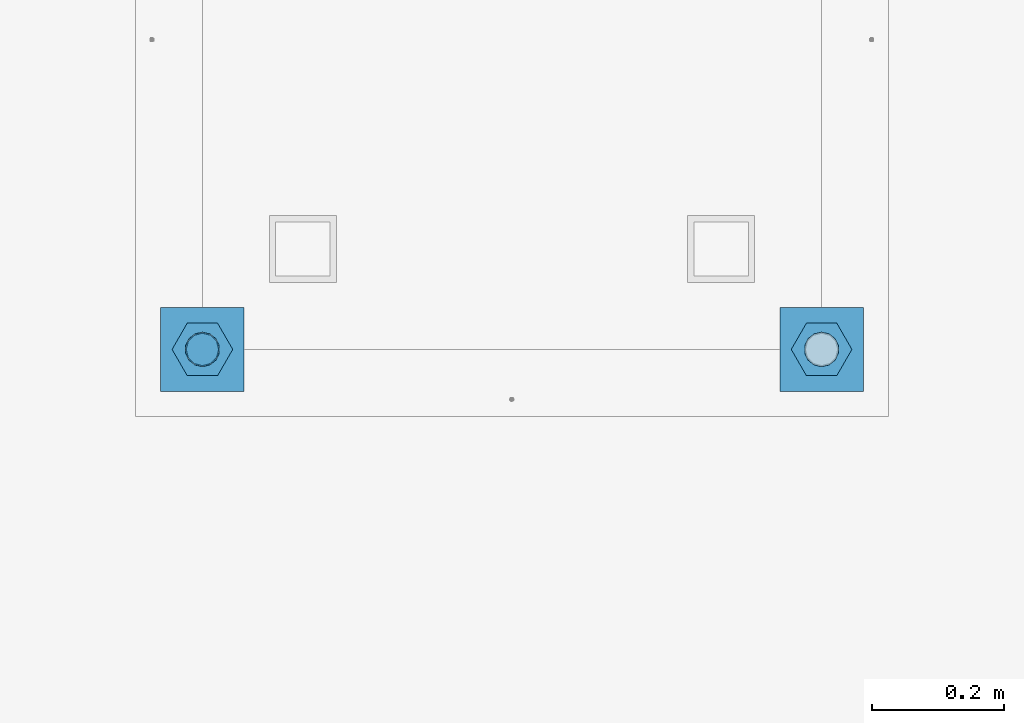
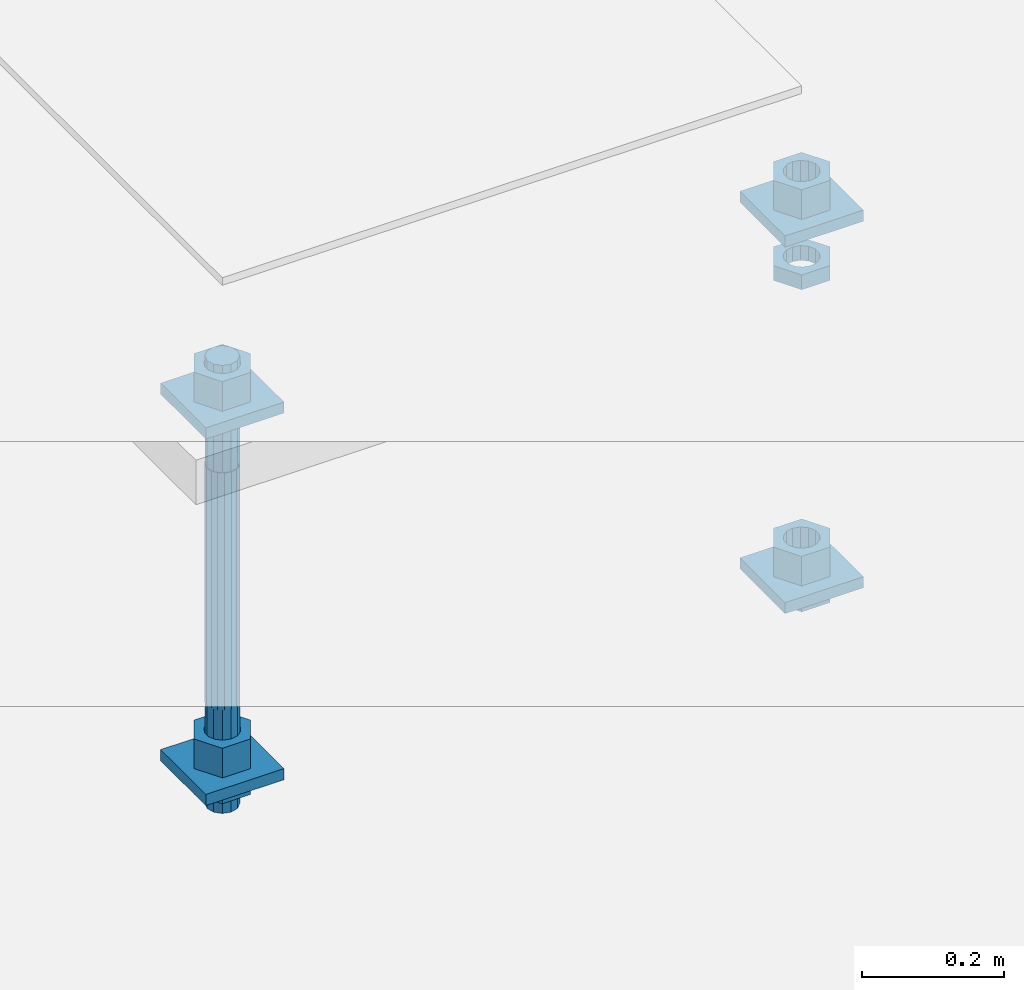
# One storey, part 2601 of 3843: 12 beams, 1 element without a shape of its own.
"""IFC2X3 building model written with IfcOpenShell, lengths in millimetres."""

from ifc_helpers import new_model, si_unit, frame, origin_with_axes, place, context, subcontext, project, spatial, faceted_brep, material, type_object, element, aggregate, save


model = new_model("IFC2X3")

# Units and contexts
model_context = context("Model", 3, precision=1e-05, world=origin_with_axes())
body_context = subcontext(model_context, "Body", "Model", "MODEL_VIEW")
ifc_project = project(units=[si_unit("LENGTHUNIT", "METRE", prefix="MILLI"), si_unit("AREAUNIT", "SQUARE_METRE"), si_unit("VOLUMEUNIT", "CUBIC_METRE"), si_unit("MASSUNIT", "GRAM", prefix="KILO"), si_unit("TIMEUNIT", "SECOND"), si_unit("PLANEANGLEUNIT", "RADIAN"), si_unit("SOLIDANGLEUNIT", "STERADIAN"), si_unit("THERMODYNAMICTEMPERATUREUNIT", "DEGREE_CELSIUS"), si_unit("LUMINOUSINTENSITYUNIT", "LUMEN")], contexts=[model_context])

# Site, building, storey
site_placement = place(None, origin_with_axes())
site = spatial("IfcSite", under=ifc_project, at=site_placement, CompositionType="ELEMENT")
building_placement = place(site_placement, origin_with_axes())
building = spatial("IfcBuilding", under=site, at=building_placement, Name="Undefined", CompositionType="ELEMENT")
storey_placement = place(building_placement, origin_with_axes())
storey = spatial("IfcBuildingStorey", under=building, at=storey_placement, Name="Undefined", CompositionType="ELEMENT", Elevation=0.0)

# Assembly, beams
assembly_placement = place(storey_placement, origin_with_axes())
assembly = element("IfcElementAssembly", 1, at=assembly_placement, inside=storey, Name="TEMPLATE", AssemblyPlace="NOTDEFINED", PredefinedType="RIGID_FRAME")
ifc_material_1 = material(Name="STEEL/A36")
beam_type_1 = type_object("IfcBeamType", PredefinedType="NOTDEFINED")
beam_1_placement = place(assembly_placement, frame((108483.4, 21551.9000015259, 29873.575), z_axis=(1.0, 0.0, 0.0), x_axis=(0.0, 1.0, 0.0)))
beam_1 = element("IfcBeam", 2, at=beam_1_placement, type_object=beam_type_1, material=ifc_material_1, Name="WASHER_PLATE", context=body_context, shape_type="Brep", body=[
    faceted_brep([(0.0, 9.52500000000146, -63.5), (0.0, 9.52500000000146, 63.5), (127.0, 9.52500000000146, 63.5), (127.0, 9.52500000000146, -63.5), (0.0, -9.52500000000146, 63.5), (127.0, -9.52500000000146, 63.5), (0.0, -9.52500000000146, -63.5), (127.0, -9.52500000000146, -63.5)], [[[0, 1, 2, 3]], [[1, 4, 5, 2]], [[4, 6, 7, 5]], [[6, 0, 3, 7]], [[5, 7, 3, 2]], [[6, 4, 1, 0]]]),
])
beam_2_placement = place(assembly_placement, frame((109423.2, 21551.9000015259, 29873.575), z_axis=(1.0, 0.0, 0.0), x_axis=(0.0, 1.0, 0.0)))
beam_2 = element("IfcBeam", 3, at=beam_2_placement, type_object=beam_type_1, material=ifc_material_1, Name="WASHER_PLATE", context=body_context, shape_type="Brep", body=[
    faceted_brep([(0.0, 9.52500000000146, -63.5), (0.0, 9.52500000000146, 63.5), (127.0, 9.52500000000146, 63.5), (127.0, 9.52500000000146, -63.5), (0.0, -9.52500000000146, 63.5), (127.0, -9.52500000000146, 63.5), (0.0, -9.52500000000146, -63.5), (127.0, -9.52500000000146, -63.5)], [[[0, 1, 2, 3]], [[1, 4, 5, 2]], [[4, 6, 7, 5]], [[6, 0, 3, 7]], [[5, 7, 3, 2]], [[6, 4, 1, 0]]]),
])
beam_3_placement = place(assembly_placement, frame((108483.4, 21551.9000015259, 29244.925), z_axis=(1.0, 0.0, 0.0), x_axis=(0.0, 1.0, 0.0)))
beam_3 = element("IfcBeam", 4, at=beam_3_placement, type_object=beam_type_1, material=ifc_material_1, Name="WASHER_PLATE", context=body_context, shape_type="Brep", body=[
    faceted_brep([(0.0, 9.52500000000146, -63.5), (0.0, 9.52500000000146, 63.5), (127.0, 9.52500000000146, 63.5), (127.0, 9.52500000000146, -63.5), (0.0, -9.52500000000146, 63.5), (127.0, -9.52500000000146, 63.5), (0.0, -9.52500000000146, -63.5), (127.0, -9.52500000000146, -63.5)], [[[0, 1, 2, 3]], [[1, 4, 5, 2]], [[4, 6, 7, 5]], [[6, 0, 3, 7]], [[5, 7, 3, 2]], [[6, 4, 1, 0]]]),
])
beam_4_placement = place(assembly_placement, frame((109423.2, 21551.9000015259, 29244.925), z_axis=(1.0, 0.0, 0.0), x_axis=(0.0, 1.0, 0.0)))
beam_4 = element("IfcBeam", 5, at=beam_4_placement, type_object=beam_type_1, material=ifc_material_1, Name="WASHER_PLATE", context=body_context, shape_type="Brep", body=[
    faceted_brep([(0.0, 9.52500000000146, -63.5), (0.0, 9.52500000000146, 63.5), (127.0, 9.52500000000146, 63.5), (127.0, 9.52500000000146, -63.5), (0.0, -9.52500000000146, 63.5), (127.0, -9.52500000000146, 63.5), (0.0, -9.52500000000146, -63.5), (127.0, -9.52500000000146, -63.5)], [[[0, 1, 2, 3]], [[1, 4, 5, 2]], [[4, 6, 7, 5]], [[6, 0, 3, 7]], [[5, 7, 3, 2]], [[6, 4, 1, 0]]]),
])
beam_type_2 = type_object("IfcBeamType", Name="2_HALF_NUT", PredefinedType="NOTDEFINED")
beam_5_placement = place(assembly_placement, frame((109423.2, 21615.4000015259, 29787.85), z_axis=(0.0, 1.0, 0.0), x_axis=(0.0, 0.0, -1.0)))
beam_5 = element("IfcBeam", 6, at=beam_5_placement, type_object=beam_type_2, material=ifc_material_1, Name="NUT", ObjectType="2_HALF_NUT", context=body_context, shape_type="Brep", body=[
    faceted_brep([(0.0, -46.0369987487793, 0.0), (0.0, -23.0184993743896, -39.869213104248), (25.4000000000015, -23.0184993743896, -39.869213104248), (25.4000000000015, -46.0369987487793, 0.0), (0.0, 23.0184993743896, -39.869213104248), (25.4000000000015, 23.0184993743896, -39.869213104248), (0.0, 46.0369987487793, 0.0), (25.4000000000015, 46.0369987487793, 0.0), (0.0, 23.0184993743896, 39.869213104248), (25.4000000000015, 23.0184993743896, 39.869213104248), (0.0, -23.0184993743896, 39.869213104248), (25.4000000000015, -23.0184993743896, 39.869213104248), (0.0, 0.0, 26.1940002441406), (0.0, 11.3650617044477, 23.5999013092805), (25.4000000000015, 11.3650617044477, 23.5999013092805), (25.4000000000015, 0.0, 26.1940002441406), (0.0, 20.4791109456419, 16.3316083006721), (25.4000000000015, 20.4791109456419, 16.3316083006721), (0.0, 25.5370200498292, 5.82867859874386), (25.4000000000015, 25.5370200498292, 5.82867859874386), (0.0, 25.5370200498292, -5.82867859874386), (25.4000000000015, 25.5370200498292, -5.82867859874386), (0.0, 20.4791109456419, -16.3316083006721), (25.4000000000015, 20.4791109456419, -16.3316083006721), (0.0, 11.3650617044477, -23.5999013092805), (25.4000000000015, 11.3650617044477, -23.5999013092805), (0.0, 0.0, -26.1940002441406), (25.4000000000015, 0.0, -26.1940002441406), (0.0, -11.3650617044477, -23.5999013092805), (25.4000000000015, -11.3650617044477, -23.5999013092805), (0.0, -20.4791109456419, -16.3316083006721), (25.4000000000015, -20.4791109456419, -16.3316083006721), (0.0, -25.5370200498292, -5.82867859874386), (25.4000000000015, -25.5370200498292, -5.82867859874386), (0.0, -25.5370200498292, 5.82867859874386), (25.4000000000015, -25.5370200498292, 5.82867859874386), (0.0, -20.4791109456419, 16.3316083006721), (25.4000000000015, -20.4791109456419, 16.3316083006721), (0.0, -11.3650617044477, 23.5999013092805), (25.4000000000015, -11.3650617044477, 23.5999013092805)], [[[0, 1, 2, 3]], [[1, 4, 5, 2]], [[4, 6, 7, 5]], [[6, 8, 9, 7]], [[8, 10, 11, 9]], [[10, 0, 3, 11]], [[12, 13, 14, 15]], [[13, 16, 17, 14]], [[16, 18, 19, 17]], [[18, 20, 21, 19]], [[20, 22, 23, 21]], [[22, 24, 25, 23]], [[24, 26, 27, 25]], [[26, 28, 29, 27]], [[28, 30, 31, 29]], [[30, 32, 33, 31]], [[32, 34, 35, 33]], [[34, 36, 37, 35]], [[36, 38, 39, 37]], [[38, 12, 15, 39]], [[5, 7, 9, 11, 3, 2], [17, 19, 21, 23, 25, 27, 29, 31, 33, 35, 37, 39, 15, 14]], [[10, 8, 6, 4, 1, 0], [38, 36, 34, 32, 30, 28, 26, 24, 22, 20, 18, 16, 13, 12]]]),
])
beam_6_placement = place(assembly_placement, frame((108483.4, 21615.4000015259, 29235.4), z_axis=(0.0, -1.0, 0.0), x_axis=(0.0, 0.0, -1.0)))
beam_6 = element("IfcBeam", 7, at=beam_6_placement, type_object=beam_type_2, material=ifc_material_1, Name="NUT", ObjectType="2_HALF_NUT", context=body_context, shape_type="Brep", body=[
    faceted_brep([(0.0, -46.0369987487793, 0.0), (0.0, -23.0184993743896, -39.869213104248), (25.4000000000015, -23.0184993743896, -39.869213104248), (25.4000000000015, -46.0369987487793, 0.0), (0.0, 23.0184993743896, -39.869213104248), (25.4000000000015, 23.0184993743896, -39.869213104248), (0.0, 46.0369987487793, 0.0), (25.4000000000015, 46.0369987487793, 0.0), (0.0, 23.0184993743896, 39.869213104248), (25.4000000000015, 23.0184993743896, 39.869213104248), (0.0, -23.0184993743896, 39.869213104248), (25.4000000000015, -23.0184993743896, 39.869213104248), (0.0, 0.0, 26.1940002441406), (0.0, 11.3650617044477, 23.5999013092805), (25.4000000000015, 11.3650617044477, 23.5999013092805), (25.4000000000015, 0.0, 26.1940002441406), (0.0, 20.4791109456419, 16.3316083006721), (25.4000000000015, 20.4791109456419, 16.3316083006721), (0.0, 25.5370200498292, 5.82867859874386), (25.4000000000015, 25.5370200498292, 5.82867859874386), (0.0, 25.5370200498292, -5.82867859874386), (25.4000000000015, 25.5370200498292, -5.82867859874386), (0.0, 20.4791109456419, -16.3316083006721), (25.4000000000015, 20.4791109456419, -16.3316083006721), (0.0, 11.3650617044477, -23.5999013092805), (25.4000000000015, 11.3650617044477, -23.5999013092805), (0.0, 0.0, -26.1940002441406), (25.4000000000015, 0.0, -26.1940002441406), (0.0, -11.3650617044477, -23.5999013092805), (25.4000000000015, -11.3650617044477, -23.5999013092805), (0.0, -20.4791109456419, -16.3316083006721), (25.4000000000015, -20.4791109456419, -16.3316083006721), (0.0, -25.5370200498292, -5.82867859874386), (25.4000000000015, -25.5370200498292, -5.82867859874386), (0.0, -25.5370200498292, 5.82867859874386), (25.4000000000015, -25.5370200498292, 5.82867859874386), (0.0, -20.4791109456419, 16.3316083006721), (25.4000000000015, -20.4791109456419, 16.3316083006721), (0.0, -11.3650617044477, 23.5999013092805), (25.4000000000015, -11.3650617044477, 23.5999013092805)], [[[0, 1, 2, 3]], [[1, 4, 5, 2]], [[4, 6, 7, 5]], [[6, 8, 9, 7]], [[8, 10, 11, 9]], [[10, 0, 3, 11]], [[12, 13, 14, 15]], [[13, 16, 17, 14]], [[16, 18, 19, 17]], [[18, 20, 21, 19]], [[20, 22, 23, 21]], [[22, 24, 25, 23]], [[24, 26, 27, 25]], [[26, 28, 29, 27]], [[28, 30, 31, 29]], [[30, 32, 33, 31]], [[32, 34, 35, 33]], [[34, 36, 37, 35]], [[36, 38, 39, 37]], [[38, 12, 15, 39]], [[5, 7, 9, 11, 3, 2], [17, 19, 21, 23, 25, 27, 29, 31, 33, 35, 37, 39, 15, 14]], [[10, 8, 6, 4, 1, 0], [38, 36, 34, 32, 30, 28, 26, 24, 22, 20, 18, 16, 13, 12]]]),
])
beam_7_placement = place(assembly_placement, frame((109423.2, 21615.4000015259, 29235.4), z_axis=(0.0, 1.0, 0.0), x_axis=(0.0, 0.0, -1.0)))
beam_7 = element("IfcBeam", 8, at=beam_7_placement, type_object=beam_type_2, material=ifc_material_1, Name="NUT", ObjectType="2_HALF_NUT", context=body_context, shape_type="Brep", body=[
    faceted_brep([(0.0, -46.0369987487793, 0.0), (0.0, -23.0184993743896, -39.869213104248), (25.4000000000015, -23.0184993743896, -39.869213104248), (25.4000000000015, -46.0369987487793, 0.0), (0.0, 23.0184993743896, -39.869213104248), (25.4000000000015, 23.0184993743896, -39.869213104248), (0.0, 46.0369987487793, 0.0), (25.4000000000015, 46.0369987487793, 0.0), (0.0, 23.0184993743896, 39.869213104248), (25.4000000000015, 23.0184993743896, 39.869213104248), (0.0, -23.0184993743896, 39.869213104248), (25.4000000000015, -23.0184993743896, 39.869213104248), (0.0, 0.0, 26.1940002441406), (0.0, 11.3650617044477, 23.5999013092805), (25.4000000000015, 11.3650617044477, 23.5999013092805), (25.4000000000015, 0.0, 26.1940002441406), (0.0, 20.4791109456419, 16.3316083006721), (25.4000000000015, 20.4791109456419, 16.3316083006721), (0.0, 25.5370200498292, 5.82867859874386), (25.4000000000015, 25.5370200498292, 5.82867859874386), (0.0, 25.5370200498292, -5.82867859874386), (25.4000000000015, 25.5370200498292, -5.82867859874386), (0.0, 20.4791109456419, -16.3316083006721), (25.4000000000015, 20.4791109456419, -16.3316083006721), (0.0, 11.3650617044477, -23.5999013092805), (25.4000000000015, 11.3650617044477, -23.5999013092805), (0.0, 0.0, -26.1940002441406), (25.4000000000015, 0.0, -26.1940002441406), (0.0, -11.3650617044477, -23.5999013092805), (25.4000000000015, -11.3650617044477, -23.5999013092805), (0.0, -20.4791109456419, -16.3316083006721), (25.4000000000015, -20.4791109456419, -16.3316083006721), (0.0, -25.5370200498292, -5.82867859874386), (25.4000000000015, -25.5370200498292, -5.82867859874386), (0.0, -25.5370200498292, 5.82867859874386), (25.4000000000015, -25.5370200498292, 5.82867859874386), (0.0, -20.4791109456419, 16.3316083006721), (25.4000000000015, -20.4791109456419, 16.3316083006721), (0.0, -11.3650617044477, 23.5999013092805), (25.4000000000015, -11.3650617044477, 23.5999013092805)], [[[0, 1, 2, 3]], [[1, 4, 5, 2]], [[4, 6, 7, 5]], [[6, 8, 9, 7]], [[8, 10, 11, 9]], [[10, 0, 3, 11]], [[12, 13, 14, 15]], [[13, 16, 17, 14]], [[16, 18, 19, 17]], [[18, 20, 21, 19]], [[20, 22, 23, 21]], [[22, 24, 25, 23]], [[24, 26, 27, 25]], [[26, 28, 29, 27]], [[28, 30, 31, 29]], [[30, 32, 33, 31]], [[32, 34, 35, 33]], [[34, 36, 37, 35]], [[36, 38, 39, 37]], [[38, 12, 15, 39]], [[5, 7, 9, 11, 3, 2], [17, 19, 21, 23, 25, 27, 29, 31, 33, 35, 37, 39, 15, 14]], [[10, 8, 6, 4, 1, 0], [38, 36, 34, 32, 30, 28, 26, 24, 22, 20, 18, 16, 13, 12]]]),
])
beam_type_3 = type_object("IfcBeamType", Name="2_HEAVY_HEX_NUT", PredefinedType="NOTDEFINED")
beam_8_placement = place(assembly_placement, frame((108483.4, 21615.4000015259, 29933.9), z_axis=(0.0, -1.0, 0.0), x_axis=(0.0, 0.0, -1.0)))
beam_8 = element("IfcBeam", 9, at=beam_8_placement, type_object=beam_type_3, material=ifc_material_1, Name="NUT", ObjectType="2_HEAVY_HEX_NUT", context=body_context, shape_type="Brep", body=[
    faceted_brep([(0.0, -46.0369987487793, 0.0), (0.0, -23.0184993743896, -39.869213104248), (50.7999999999993, -23.0184993743896, -39.869213104248), (50.7999999999993, -46.0369987487793, 0.0), (0.0, 23.0184993743896, -39.869213104248), (50.7999999999993, 23.0184993743896, -39.869213104248), (0.0, 46.0369987487793, 0.0), (50.7999999999993, 46.0369987487793, 0.0), (0.0, 23.0184993743896, 39.869213104248), (50.7999999999993, 23.0184993743896, 39.869213104248), (0.0, -23.0184993743896, 39.869213104248), (50.7999999999993, -23.0184993743896, 39.869213104248), (0.0, 0.0, 26.1940002441406), (0.0, 11.3650617044477, 23.5999013092805), (50.7999999999993, 11.3650617044477, 23.5999013092805), (50.7999999999993, 0.0, 26.1940002441406), (0.0, 20.4791109456419, 16.3316083006721), (50.7999999999993, 20.4791109456419, 16.3316083006721), (0.0, 25.5370200498292, 5.82867859874386), (50.7999999999993, 25.5370200498292, 5.82867859874386), (0.0, 25.5370200498292, -5.82867859874386), (50.7999999999993, 25.5370200498292, -5.82867859874386), (0.0, 20.4791109456419, -16.3316083006721), (50.7999999999993, 20.4791109456419, -16.3316083006721), (0.0, 11.3650617044477, -23.5999013092805), (50.7999999999993, 11.3650617044477, -23.5999013092805), (0.0, 0.0, -26.1940002441406), (50.7999999999993, 0.0, -26.1940002441406), (0.0, -11.3650617044477, -23.5999013092805), (50.7999999999993, -11.3650617044477, -23.5999013092805), (0.0, -20.4791109456419, -16.3316083006721), (50.7999999999993, -20.4791109456419, -16.3316083006721), (0.0, -25.5370200498292, -5.82867859874386), (50.7999999999993, -25.5370200498292, -5.82867859874386), (0.0, -25.5370200498292, 5.82867859874386), (50.7999999999993, -25.5370200498292, 5.82867859874386), (0.0, -20.4791109456419, 16.3316083006721), (50.7999999999993, -20.4791109456419, 16.3316083006721), (0.0, -11.3650617044477, 23.5999013092805), (50.7999999999993, -11.3650617044477, 23.5999013092805)], [[[0, 1, 2, 3]], [[1, 4, 5, 2]], [[4, 6, 7, 5]], [[6, 8, 9, 7]], [[8, 10, 11, 9]], [[10, 0, 3, 11]], [[12, 13, 14, 15]], [[13, 16, 17, 14]], [[16, 18, 19, 17]], [[18, 20, 21, 19]], [[20, 22, 23, 21]], [[22, 24, 25, 23]], [[24, 26, 27, 25]], [[26, 28, 29, 27]], [[28, 30, 31, 29]], [[30, 32, 33, 31]], [[32, 34, 35, 33]], [[34, 36, 37, 35]], [[36, 38, 39, 37]], [[38, 12, 15, 39]], [[5, 7, 9, 11, 3, 2], [17, 19, 21, 23, 25, 27, 29, 31, 33, 35, 37, 39, 15, 14]], [[10, 8, 6, 4, 1, 0], [38, 36, 34, 32, 30, 28, 26, 24, 22, 20, 18, 16, 13, 12]]]),
])
beam_9_placement = place(assembly_placement, frame((108483.4, 21615.4000015259, 29305.25), z_axis=(0.0, -1.0, 0.0), x_axis=(0.0, 0.0, -1.0)))
beam_9 = element("IfcBeam", 10, at=beam_9_placement, type_object=beam_type_3, material=ifc_material_1, Name="NUT", ObjectType="2_HEAVY_HEX_NUT", context=body_context, shape_type="Brep", body=[
    faceted_brep([(0.0, -46.0369987487793, 0.0), (0.0, -23.0184993743896, -39.869213104248), (50.7999999999993, -23.0184993743896, -39.869213104248), (50.7999999999993, -46.0369987487793, 0.0), (0.0, 23.0184993743896, -39.869213104248), (50.7999999999993, 23.0184993743896, -39.869213104248), (0.0, 46.0369987487793, 0.0), (50.7999999999993, 46.0369987487793, 0.0), (0.0, 23.0184993743896, 39.869213104248), (50.7999999999993, 23.0184993743896, 39.869213104248), (0.0, -23.0184993743896, 39.869213104248), (50.7999999999993, -23.0184993743896, 39.869213104248), (0.0, 0.0, 26.1940002441406), (0.0, 11.3650617044477, 23.5999013092805), (50.7999999999993, 11.3650617044477, 23.5999013092805), (50.7999999999993, 0.0, 26.1940002441406), (0.0, 20.4791109456419, 16.3316083006721), (50.7999999999993, 20.4791109456419, 16.3316083006721), (0.0, 25.5370200498292, 5.82867859874386), (50.7999999999993, 25.5370200498292, 5.82867859874386), (0.0, 25.5370200498292, -5.82867859874386), (50.7999999999993, 25.5370200498292, -5.82867859874386), (0.0, 20.4791109456419, -16.3316083006721), (50.7999999999993, 20.4791109456419, -16.3316083006721), (0.0, 11.3650617044477, -23.5999013092805), (50.7999999999993, 11.3650617044477, -23.5999013092805), (0.0, 0.0, -26.1940002441406), (50.7999999999993, 0.0, -26.1940002441406), (0.0, -11.3650617044477, -23.5999013092805), (50.7999999999993, -11.3650617044477, -23.5999013092805), (0.0, -20.4791109456419, -16.3316083006721), (50.7999999999993, -20.4791109456419, -16.3316083006721), (0.0, -25.5370200498292, -5.82867859874386), (50.7999999999993, -25.5370200498292, -5.82867859874386), (0.0, -25.5370200498292, 5.82867859874386), (50.7999999999993, -25.5370200498292, 5.82867859874386), (0.0, -20.4791109456419, 16.3316083006721), (50.7999999999993, -20.4791109456419, 16.3316083006721), (0.0, -11.3650617044477, 23.5999013092805), (50.7999999999993, -11.3650617044477, 23.5999013092805)], [[[0, 1, 2, 3]], [[1, 4, 5, 2]], [[4, 6, 7, 5]], [[6, 8, 9, 7]], [[8, 10, 11, 9]], [[10, 0, 3, 11]], [[12, 13, 14, 15]], [[13, 16, 17, 14]], [[16, 18, 19, 17]], [[18, 20, 21, 19]], [[20, 22, 23, 21]], [[22, 24, 25, 23]], [[24, 26, 27, 25]], [[26, 28, 29, 27]], [[28, 30, 31, 29]], [[30, 32, 33, 31]], [[32, 34, 35, 33]], [[34, 36, 37, 35]], [[36, 38, 39, 37]], [[38, 12, 15, 39]], [[5, 7, 9, 11, 3, 2], [17, 19, 21, 23, 25, 27, 29, 31, 33, 35, 37, 39, 15, 14]], [[10, 8, 6, 4, 1, 0], [38, 36, 34, 32, 30, 28, 26, 24, 22, 20, 18, 16, 13, 12]]]),
])
beam_10_placement = place(assembly_placement, frame((109423.2, 21615.4000015259, 29933.9), z_axis=(0.0, 1.0, 0.0), x_axis=(0.0, 0.0, -1.0)))
beam_10 = element("IfcBeam", 11, at=beam_10_placement, type_object=beam_type_3, material=ifc_material_1, Name="NUT", ObjectType="2_HEAVY_HEX_NUT", context=body_context, shape_type="Brep", body=[
    faceted_brep([(0.0, -46.0369987487793, 0.0), (0.0, -23.0184993743896, -39.869213104248), (50.7999999999993, -23.0184993743896, -39.869213104248), (50.7999999999993, -46.0369987487793, 0.0), (0.0, 23.0184993743896, -39.869213104248), (50.7999999999993, 23.0184993743896, -39.869213104248), (0.0, 46.0369987487793, 0.0), (50.7999999999993, 46.0369987487793, 0.0), (0.0, 23.0184993743896, 39.869213104248), (50.7999999999993, 23.0184993743896, 39.869213104248), (0.0, -23.0184993743896, 39.869213104248), (50.7999999999993, -23.0184993743896, 39.869213104248), (0.0, 0.0, 26.1940002441406), (0.0, 11.3650617044477, 23.5999013092805), (50.7999999999993, 11.3650617044477, 23.5999013092805), (50.7999999999993, 0.0, 26.1940002441406), (0.0, 20.4791109456419, 16.3316083006721), (50.7999999999993, 20.4791109456419, 16.3316083006721), (0.0, 25.5370200498292, 5.82867859874386), (50.7999999999993, 25.5370200498292, 5.82867859874386), (0.0, 25.5370200498292, -5.82867859874386), (50.7999999999993, 25.5370200498292, -5.82867859874386), (0.0, 20.4791109456419, -16.3316083006721), (50.7999999999993, 20.4791109456419, -16.3316083006721), (0.0, 11.3650617044477, -23.5999013092805), (50.7999999999993, 11.3650617044477, -23.5999013092805), (0.0, 0.0, -26.1940002441406), (50.7999999999993, 0.0, -26.1940002441406), (0.0, -11.3650617044477, -23.5999013092805), (50.7999999999993, -11.3650617044477, -23.5999013092805), (0.0, -20.4791109456419, -16.3316083006721), (50.7999999999993, -20.4791109456419, -16.3316083006721), (0.0, -25.5370200498292, -5.82867859874386), (50.7999999999993, -25.5370200498292, -5.82867859874386), (0.0, -25.5370200498292, 5.82867859874386), (50.7999999999993, -25.5370200498292, 5.82867859874386), (0.0, -20.4791109456419, 16.3316083006721), (50.7999999999993, -20.4791109456419, 16.3316083006721), (0.0, -11.3650617044477, 23.5999013092805), (50.7999999999993, -11.3650617044477, 23.5999013092805)], [[[0, 1, 2, 3]], [[1, 4, 5, 2]], [[4, 6, 7, 5]], [[6, 8, 9, 7]], [[8, 10, 11, 9]], [[10, 0, 3, 11]], [[12, 13, 14, 15]], [[13, 16, 17, 14]], [[16, 18, 19, 17]], [[18, 20, 21, 19]], [[20, 22, 23, 21]], [[22, 24, 25, 23]], [[24, 26, 27, 25]], [[26, 28, 29, 27]], [[28, 30, 31, 29]], [[30, 32, 33, 31]], [[32, 34, 35, 33]], [[34, 36, 37, 35]], [[36, 38, 39, 37]], [[38, 12, 15, 39]], [[5, 7, 9, 11, 3, 2], [17, 19, 21, 23, 25, 27, 29, 31, 33, 35, 37, 39, 15, 14]], [[10, 8, 6, 4, 1, 0], [38, 36, 34, 32, 30, 28, 26, 24, 22, 20, 18, 16, 13, 12]]]),
])
beam_11_placement = place(assembly_placement, frame((109423.2, 21615.4000015259, 29305.25), z_axis=(0.0, 1.0, 0.0), x_axis=(0.0, 0.0, -1.0)))
beam_11 = element("IfcBeam", 12, at=beam_11_placement, type_object=beam_type_3, material=ifc_material_1, Name="NUT", ObjectType="2_HEAVY_HEX_NUT", context=body_context, shape_type="Brep", body=[
    faceted_brep([(0.0, -46.0369987487793, 0.0), (0.0, -23.0184993743896, -39.869213104248), (50.7999999999993, -23.0184993743896, -39.869213104248), (50.7999999999993, -46.0369987487793, 0.0), (0.0, 23.0184993743896, -39.869213104248), (50.7999999999993, 23.0184993743896, -39.869213104248), (0.0, 46.0369987487793, 0.0), (50.7999999999993, 46.0369987487793, 0.0), (0.0, 23.0184993743896, 39.869213104248), (50.7999999999993, 23.0184993743896, 39.869213104248), (0.0, -23.0184993743896, 39.869213104248), (50.7999999999993, -23.0184993743896, 39.869213104248), (0.0, 0.0, 26.1940002441406), (0.0, 11.3650617044477, 23.5999013092805), (50.7999999999993, 11.3650617044477, 23.5999013092805), (50.7999999999993, 0.0, 26.1940002441406), (0.0, 20.4791109456419, 16.3316083006721), (50.7999999999993, 20.4791109456419, 16.3316083006721), (0.0, 25.5370200498292, 5.82867859874386), (50.7999999999993, 25.5370200498292, 5.82867859874386), (0.0, 25.5370200498292, -5.82867859874386), (50.7999999999993, 25.5370200498292, -5.82867859874386), (0.0, 20.4791109456419, -16.3316083006721), (50.7999999999993, 20.4791109456419, -16.3316083006721), (0.0, 11.3650617044477, -23.5999013092805), (50.7999999999993, 11.3650617044477, -23.5999013092805), (0.0, 0.0, -26.1940002441406), (50.7999999999993, 0.0, -26.1940002441406), (0.0, -11.3650617044477, -23.5999013092805), (50.7999999999993, -11.3650617044477, -23.5999013092805), (0.0, -20.4791109456419, -16.3316083006721), (50.7999999999993, -20.4791109456419, -16.3316083006721), (0.0, -25.5370200498292, -5.82867859874386), (50.7999999999993, -25.5370200498292, -5.82867859874386), (0.0, -25.5370200498292, 5.82867859874386), (50.7999999999993, -25.5370200498292, 5.82867859874386), (0.0, -20.4791109456419, 16.3316083006721), (50.7999999999993, -20.4791109456419, 16.3316083006721), (0.0, -11.3650617044477, 23.5999013092805), (50.7999999999993, -11.3650617044477, 23.5999013092805)], [[[0, 1, 2, 3]], [[1, 4, 5, 2]], [[4, 6, 7, 5]], [[6, 8, 9, 7]], [[8, 10, 11, 9]], [[10, 0, 3, 11]], [[12, 13, 14, 15]], [[13, 16, 17, 14]], [[16, 18, 19, 17]], [[18, 20, 21, 19]], [[20, 22, 23, 21]], [[22, 24, 25, 23]], [[24, 26, 27, 25]], [[26, 28, 29, 27]], [[28, 30, 31, 29]], [[30, 32, 33, 31]], [[32, 34, 35, 33]], [[34, 36, 37, 35]], [[36, 38, 39, 37]], [[38, 12, 15, 39]], [[5, 7, 9, 11, 3, 2], [17, 19, 21, 23, 25, 27, 29, 31, 33, 35, 37, 39, 15, 14]], [[10, 8, 6, 4, 1, 0], [38, 36, 34, 32, 30, 28, 26, 24, 22, 20, 18, 16, 13, 12]]]),
])
ifc_material_2 = material()
beam_type_4 = type_object("IfcBeamType", PredefinedType="NOTDEFINED")
beam_12_placement = place(assembly_placement, frame((108483.4, 21615.4000015259, 29762.45), z_axis=(0.0, -1.0, 0.0), x_axis=(0.0, 0.0, -1.0)))
beam_12 = element("IfcBeam", 13, at=beam_12_placement, type_object=beam_type_4, material=ifc_material_2, Name="ANCHOR_ROD", context=body_context, shape_type="Brep", body=[
    faceted_brep([(-184.150000000001, -21.217622392709, 12.25), (-184.150000000001, -12.2499999999854, 21.2176223927163), (-184.150000000001, 1.45519152283669e-11, 24.5), (-184.150000000001, 12.2500000000146, 21.2176223927163), (-184.150000000001, 21.2176223927381, 12.25), (-184.150000000001, 24.5000000000146, 0.0), (-184.150000000001, 21.2176223927381, -12.25), (-184.150000000001, 12.2500000000146, -21.2176223927163), (-184.150000000001, 1.45519152283669e-11, -24.5), (-184.150000000001, -12.2499999999854, -21.2176223927163), (-184.150000000001, -21.217622392709, -12.25), (-184.150000000001, -24.4999999999854, 0.0), (0.0, 24.5000000000146, 0.0), (0.0, 21.2176223927381, -12.25), (0.0, 12.2500000000146, -21.2176223927163), (0.0, 1.45519152283669e-11, -24.5), (0.0, -12.2499999999854, -21.2176223927163), (0.0, -21.217622392709, -12.25), (0.0, -24.4999999999854, 0.0), (0.0, -21.217622392709, 12.25), (0.0, -12.2499999999854, 21.2176223927163), (0.0, 1.45519152283669e-11, 24.5), (0.0, 12.2500000000146, 21.2176223927163), (0.0, 21.2176223927381, 12.25), (0.0, -23.4665401257807, 9.72015918207035), (0.0, -17.9605122421344, 17.9605122421417), (0.0, -9.72015918207762, 23.466540125788), (0.0, 0.0, 25.4000000000015), (0.0, 9.72015918207762, 23.466540125788), (0.0, 17.9605122421344, 17.9605122421417), (0.0, 23.4665401257807, 9.72015918207035), (0.0, 25.3999996185303, 0.0), (0.0, 23.4665401257807, -9.72015918207035), (0.0, 17.9605122421344, -17.9605122421417), (0.0, 9.72015918207762, -23.466540125788), (0.0, 0.0, -25.4000000000015), (0.0, -9.72015918207762, -23.466540125788), (0.0, -17.9605122421344, -17.9605122421417), (0.0, -23.4665401257807, -9.72015918207035), (0.0, -25.3999996185303, 0.0), (406.399999999998, -25.3999999999942, 0.0), (406.399999999998, -23.4665401257807, 9.72015918207035), (406.399999999998, -17.9605122421344, 17.9605122421417), (406.399999999998, -9.72015918207762, 23.466540125788), (406.399999999998, 0.0, 25.4000000000015), (406.399999999998, 9.72015918207762, 23.466540125788), (406.399999999998, 17.9605122421344, 17.9605122421417), (406.399999999998, 23.4665401257807, 9.72015918207035), (406.399999999998, 25.3999999999942, 0.0), (406.399999999998, 23.4665401257807, -9.72015918207035), (406.399999999998, 17.9605122421344, -17.9605122421417), (406.399999999998, 9.72015918207762, -23.466540125788), (406.399999999998, 0.0, -25.4000000000015), (406.399999999998, -9.72015918207762, -23.466540125788), (406.399999999998, -17.9605122421344, -17.9605122421417), (406.399999999998, -23.4665401257807, -9.72015918207035), (406.399999999998, -12.2499999999854, 21.2176223927163), (406.399999999998, 1.45519152283669e-11, 24.5), (406.399999999998, 12.2500000000146, 21.2176223927163), (406.399999999998, 21.2176223927381, 12.25), (406.399999999998, 24.5000000000146, 0.0), (406.399999999998, 21.2176223927381, -12.25), (406.399999999998, 12.2500000000146, -21.2176223927163), (406.399999999998, 1.45519152283669e-11, -24.5), (406.399999999998, -12.2499999999854, -21.2176223927163), (406.399999999998, -21.217622392709, -12.25), (406.399999999998, -24.4999999999854, 0.0), (406.399999999998, -21.217622392709, 12.25), (584.200000000001, -12.2499999999854, -21.2176223927163), (584.200000000001, 1.45519152283669e-11, -24.5), (584.200000000001, 12.2500000000146, -21.2176223927163), (584.200000000001, 21.2176223927381, -12.25), (584.200000000001, 24.5000000000146, 0.0), (584.200000000001, 21.2176223927381, 12.25), (584.200000000001, 12.2500000000146, 21.2176223927163), (584.200000000001, 1.45519152283669e-11, 24.5), (584.200000000001, -12.2499999999854, 21.2176223927163), (584.200000000001, -21.217622392709, 12.25), (584.200000000001, -24.4999999999854, 0.0), (584.200000000001, -21.217622392709, -12.25)], [[[0, 1, 2, 3, 4, 5, 6, 7, 8, 9, 10, 11]], [[6, 5, 12, 13]], [[7, 6, 13, 14]], [[8, 7, 14, 15]], [[9, 8, 15, 16]], [[10, 9, 16, 17]], [[11, 10, 17, 18]], [[0, 11, 18, 19]], [[1, 0, 19, 20]], [[2, 1, 20, 21]], [[3, 2, 21, 22]], [[4, 3, 22, 23]], [[5, 4, 23, 12]], [[24, 25, 26, 27, 28, 29, 30, 31, 32, 33, 34, 35, 36, 37, 38, 39], [22, 21, 20, 19, 18, 17, 16, 15, 14, 13, 12, 23]], [[24, 39, 40, 41]], [[25, 24, 41, 42]], [[26, 25, 42, 43]], [[27, 26, 43, 44]], [[28, 27, 44, 45]], [[29, 28, 45, 46]], [[30, 29, 46, 47]], [[31, 30, 47, 48]], [[32, 31, 48, 49]], [[33, 32, 49, 50]], [[34, 33, 50, 51]], [[35, 34, 51, 52]], [[36, 35, 52, 53]], [[37, 36, 53, 54]], [[38, 37, 54, 55]], [[39, 38, 55, 40]], [[54, 53, 52, 51, 50, 49, 48, 47, 46, 45, 44, 43, 42, 41, 40, 55], [56, 57, 58, 59, 60, 61, 62, 63, 64, 65, 66, 67]], [[68, 69, 70, 71, 72, 73, 74, 75, 76, 77, 78, 79]], [[76, 75, 57, 56]], [[77, 76, 56, 67]], [[78, 77, 67, 66]], [[79, 78, 66, 65]], [[68, 79, 65, 64]], [[69, 68, 64, 63]], [[70, 69, 63, 62]], [[71, 70, 62, 61]], [[72, 71, 61, 60]], [[73, 72, 60, 59]], [[74, 73, 59, 58]], [[75, 74, 58, 57]]]),
])
aggregate(assembly, [beam_5, beam_1, beam_2, beam_8, beam_9, beam_6, beam_3, beam_12, beam_10, beam_11, beam_7, beam_4])

save(model, "model.ifc")
